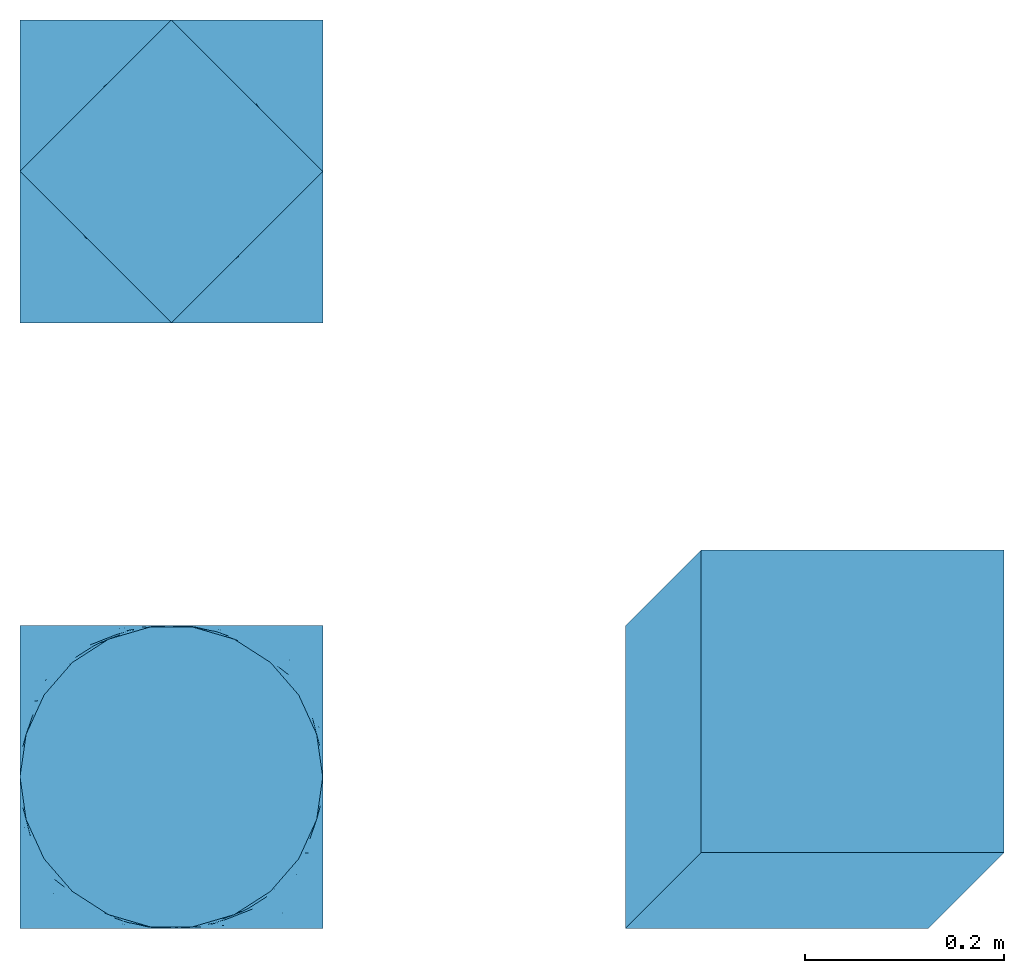
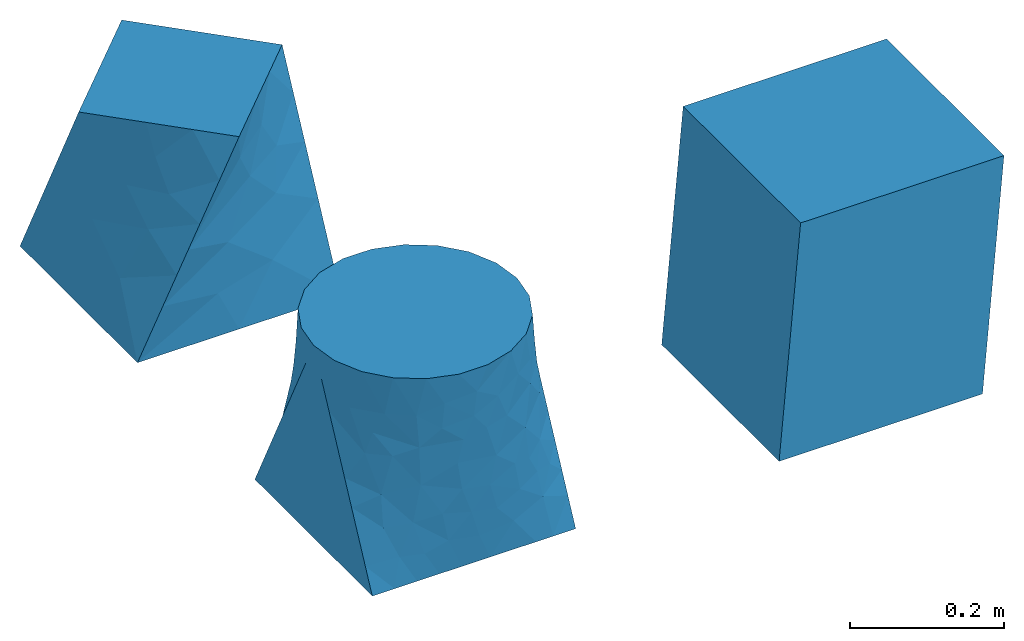
# One storey: 3 walls.
"""IFC2X3 building model written with IfcOpenShell, lengths in feet."""

from ifc_helpers import new_model, entity, si_unit, converted_unit, derived_unit, direction, frame, origin, place, context, subcontext, project, spatial, faceted_brep, type_object, element, save


model = new_model("IFC2X3")

# Units and contexts
model_context = context("Model", 3, precision=0.0001, world=origin(), true_north=direction((6.12303176911189e-17, 1.0)))
body_context = subcontext(model_context, "Body", "Model", "MODEL_VIEW")
ifc_project = project(units=[converted_unit("LENGTHUNIT", "FOOT", entity("IfcRatioMeasure", 0.3048), si_unit("LENGTHUNIT", "METRE"), dimensions=[1, 0, 0, 0, 0, 0, 0]), converted_unit("AREAUNIT", "SQUARE FOOT", entity("IfcRatioMeasure", 0.09290304), si_unit("AREAUNIT", "SQUARE_METRE"), dimensions=[2, 0, 0, 0, 0, 0, 0]), converted_unit("VOLUMEUNIT", "CUBIC FOOT", entity("IfcRatioMeasure", 0.028316846592), si_unit("VOLUMEUNIT", "CUBIC_METRE"), dimensions=[3, 0, 0, 0, 0, 0, 0]), converted_unit("PLANEANGLEUNIT", "DEGREE", entity("IfcRatioMeasure", 0.0174532925199433), si_unit("PLANEANGLEUNIT", "RADIAN"), dimensions=[0, 0, 0, 0, 0, 0, 0]), si_unit("MASSUNIT", "GRAM", prefix="KILO"), derived_unit("MASSDENSITYUNIT", [(si_unit("MASSUNIT", "GRAM", prefix="KILO"), 1), (si_unit("LENGTHUNIT", "METRE"), -3)]), si_unit("TIMEUNIT", "SECOND"), si_unit("FREQUENCYUNIT", "HERTZ"), si_unit("THERMODYNAMICTEMPERATUREUNIT", "DEGREE_CELSIUS"), derived_unit("THERMALTRANSMITTANCEUNIT", [(si_unit("MASSUNIT", "GRAM", prefix="KILO"), 1), (si_unit("THERMODYNAMICTEMPERATUREUNIT", "KELVIN"), -1), (si_unit("TIMEUNIT", "SECOND"), -3)]), derived_unit("VOLUMETRICFLOWRATEUNIT", [(si_unit("LENGTHUNIT", "METRE"), 3), (si_unit("TIMEUNIT", "SECOND"), -1)]), si_unit("ELECTRICCURRENTUNIT", "AMPERE"), si_unit("ELECTRICVOLTAGEUNIT", "VOLT"), si_unit("POWERUNIT", "WATT"), si_unit("FORCEUNIT", "NEWTON"), si_unit("ILLUMINANCEUNIT", "LUX"), si_unit("LUMINOUSFLUXUNIT", "LUMEN"), si_unit("LUMINOUSINTENSITYUNIT", "CANDELA"), derived_unit("USERDEFINED", [(si_unit("MASSUNIT", "GRAM", prefix="KILO"), -1), (si_unit("LENGTHUNIT", "METRE"), -2), (si_unit("TIMEUNIT", "SECOND"), 3), (si_unit("LUMINOUSFLUXUNIT", "LUMEN"), 1)]), derived_unit("LINEARVELOCITYUNIT", [(si_unit("LENGTHUNIT", "METRE"), 1), (si_unit("TIMEUNIT", "SECOND"), -1)]), si_unit("PRESSUREUNIT", "PASCAL"), derived_unit("USERDEFINED", [(si_unit("LENGTHUNIT", "METRE"), -2), (si_unit("MASSUNIT", "GRAM", prefix="KILO"), 1), (si_unit("TIMEUNIT", "SECOND"), -2)])], contexts=[model_context])

# Site, building, storey
site_placement = place(None, origin())
site = spatial("IfcSite", under=ifc_project, at=site_placement, CompositionType="ELEMENT")
building_placement = place(site_placement, origin())
building = spatial("IfcBuilding", under=site, at=building_placement, CompositionType="ELEMENT")
storey_placement = place(building_placement, origin())
storey = spatial("IfcBuildingStorey", under=building, at=storey_placement, Name="Level 1", CompositionType="ELEMENT", Elevation=0.0)

# Walls
wall_type_1 = type_object("IfcWallType", Name="Walls 1", PredefinedType="NOTDEFINED")
wall_1_placement = place(storey_placement, frame((-0.499999999999997, -0.500000000000002, 0.0)))
element("IfcWall", 1, at=wall_1_placement, inside=storey, type_object=wall_type_1, Name="Walls 1:Walls 1", ObjectType="Walls 1:Walls 1", context=body_context, shape_type="Brep", body=[
    faceted_brep([(1.0, 0.0, 0.0), (0.889746791844293, 0.0, 0.0), (0.805126604077855, 0.0, 0.0), (0.720506416311416, 0.0, 0.0), (0.580759624467124, 0.0, 0.0), (0.441012832622831, 0.0, 0.0), (0.330759624467124, 0.0, 0.0), (0.220506416311416, 0.0, 0.0), (0.110253208155708, 0.0, 0.0), (0.0, 0.0, 0.0), (0.0, 1.0, 0.0), (0.110253208155708, 1.0, 0.0), (0.194873395922147, 1.0, 0.0), (0.279493583688586, 1.0, 0.0), (0.419240375532878, 1.0, 0.0), (0.55898716737717, 1.0, 0.0), (0.669240375532878, 1.0, 0.0), (0.779493583688586, 1.0, 0.0), (0.889746791844293, 1.0, 0.0), (1.0, 1.0, 0.0), (1.0, 0.500000000000002, 1.0), (0.979746486807248, 0.640866278420716, 1.0), (0.920626766415589, 0.7703204087278, 1.0), (0.827430366972641, 0.877874787177129, 1.0), (0.707707506500941, 0.954815997677259, 1.0), (0.57115741913664, 0.994910720940465, 1.0), (0.428842580863355, 0.994910720940465, 1.0), (0.292292493499055, 0.954815997677257, 1.0), (0.172569633027356, 0.877874787177126, 1.0), (0.0793732335844083, 0.770320408727796, 1.0), (0.0202535131927508, 0.640866278420711, 1.0), (0.0, 0.499999999999997, 1.0), (0.0202535131927516, 0.359133721579283, 1.0), (0.07937323358441, 0.229679591272199, 1.0), (0.172569633027358, 0.122125212822869, 1.0), (0.292292493499058, 0.0451840023227389, 1.0), (0.428842580863358, 0.00508927905953199, 1.0), (0.571157419136643, 0.00508927905953216, 1.0), (0.707707506500944, 0.0451840023227395, 1.0), (0.827430366972643, 0.12212521282287, 1.0), (0.920626766415591, 0.2296795912722, 1.0), (0.979746486807249, 0.359133721579284, 1.0), (0.0, 0.566151925363885, 0.867696149272224), (0.0, 0.632303850727772, 0.735392298544452), (0.0, 0.698455776091658, 0.60308844781668), (0.0, 0.764607701455546, 0.470784597088905), (0.0, 0.823455776091659, 0.353088447816679), (0.0, 0.882303850727772, 0.235392298544454), (0.0, 0.933848074636112, 0.132303850727775), (0.0, 0.0588480871626567, 0.117696174325314), (0.0, 0.117696174325313, 0.235392348650628), (0.0, 0.176544228203926, 0.353088456407854), (0.0, 0.235392315366583, 0.470784630733168), (0.0, 0.301544253166958, 0.60308850633392), (0.0, 0.36769615768329, 0.735392315366584), (0.0, 0.433848062199621, 0.867696124399248), (0.757017197176466, 0.0674422403782831, 0.849684794978136), (0.86127441293435, 0.145324841999094, 0.84212278587982), (0.141920917585352, 0.140080615055184, 0.811733717234663), (0.616413088488513, 0.0103397471715224, 0.510515551071139), (0.583226274719934, 0.0043372230493256, 0.371454448540285), (0.72097084526604, 0.0338226130972406, 0.417342867665322), (0.849776267484753, 0.12645390141569, 0.732770100211448), (0.515653592398409, 0.000236135867766218, 0.883818607027046), (0.366038709623894, 0.0174541077744, 0.861781446516488), (0.499999979177048, 0.0, 0.760891658883891), (0.252836369415598, 0.0609001946961555, 0.810403815477062), (0.354514701637022, 0.0194400855606597, 0.735414056458186), (0.941110326458552, 0.248356510801277, 0.84968478747674), (1.0, 0.433848074636111, 0.867696149272224), (0.67940057306952, 0.0289607421539577, 0.684433992670568), (0.795731673028418, 0.0745753431820014, 0.554129477798903), (0.16068747856237, 0.106681123880739, 0.606629587667518), (0.109578540638195, 0.11459706935301, 0.418702420722298), (0.262292635672884, 0.0418228934501774, 0.458948207568247), (0.0437324972356253, 0.268445369888635, 0.801544242732555), (0.0721772541138937, 0.186598710925087, 0.603088466442167), (0.260753678036918, 0.0515044057474023, 0.64888846403325), (0.101294141878498, 0.171387659756256, 0.70951726536301), (0.101765332269067, 0.0826796673749913, 0.267954315286302), (0.223935870161411, 0.0399967995170207, 0.278852137072948), (0.565117280794555, 0.00369614575750493, 0.67589412627217), (0.450883079913483, 0.00206744369183098, 0.653250228508571), (0.89216557801141, 0.118139044305108, 0.429955188659176), (1.0, 0.235392298544452, 0.470784597088905), (0.937007672081389, 0.198619614631399, 0.607850394207608), (0.628174730663663, 0.0156186607234066, 0.812192774978989), (0.953012804727175, 0.24889982754745, 0.731724063191964), (0.152440156249403, 0.0327726145620926, 0.130177837941231), (0.527940892776347, 0.000214835338726793, 0.128507843858333), (0.70308915029569, 0.0120184609926423, 0.138334262902587), (0.744287356805821, 0.0310473672176885, 0.277682459355863), (0.618265004846732, 0.00637614198855196, 0.237606556011806), (1.0, 0.301544223908339, 0.60308844781668), (0.442937021056287, 0.00213535034225137, 0.400399859927627), (1.0, 0.0661519253638875, 0.132303850727775), (0.422853395509264, 0.00465825573982376, 0.54077192065932), (0.352201420213089, 0.0118295364385816, 0.298145323069812), (0.376428416935318, 0.00490276932154543, 0.154234560036514), (0.488544710868071, 6.49568121827704e-05, 0.266210865256215), (0.810347749233671, 0.0660190099262035, 0.392123661289816), (0.868487564693337, 0.0504441767336091, 0.183848051981968), (1.0, 0.117696149272227, 0.235392298544454), (0.936407353414507, 0.109169103430892, 0.294240360984303), (0.852390754642082, 0.0716812784062547, 0.306950602242738), (0.265622418367823, 0.0139367961617777, 0.118762404485821), (1.0, 0.367696149272225, 0.735392298544452), (1.0, 0.176544223908339, 0.353088447816679), (1.0, 0.941151912837343, 0.117696174325314), (1.0, 0.882303825674686, 0.235392348650628), (1.0, 0.823455771796074, 0.353088456407854), (1.0, 0.764607684633417, 0.470784630733168), (1.0, 0.698455746833041, 0.60308850633392), (1.0, 0.632303842316709, 0.735392315366584), (1.0, 0.566151937800378, 0.867696124399248), (0.242982802823533, 0.932557759621714, 0.849684794978136), (0.138725587065649, 0.854675158000903, 0.84212278587982), (0.858079082414647, 0.859919384944814, 0.811733717234663), (0.383586911511488, 0.989660252828476, 0.510515551071139), (0.416773725280067, 0.995662776950673, 0.371454448540285), (0.279029154733961, 0.966177386902758, 0.417342867665322), (0.150223732515247, 0.873546098584307, 0.732770100211448), (0.48434640760159, 0.999763864132231, 0.883818607027046), (0.633961290376105, 0.982545892225598, 0.861781446516488), (0.500000020822951, 1.0, 0.760891658883891), (0.747163630584401, 0.939099805303843, 0.810403815477062), (0.645485298362977, 0.980559914439338, 0.735414056458186), (0.0588896735414475, 0.751643489198719, 0.84968478747674), (0.320599426930479, 0.97103925784604, 0.684433992670568), (0.204268326971582, 0.925424656817996, 0.554129477798903), (0.83931252143763, 0.89331887611926, 0.606629587667518), (0.890421459361806, 0.885402930646989, 0.418702420722298), (0.737707364327117, 0.958177106549822, 0.458948207568247), (0.956267502764375, 0.731554630111364, 0.801544242732555), (0.927822745886107, 0.813401289074912, 0.603088466442167), (0.739246321963082, 0.948495594252596, 0.64888846403325), (0.898705858121502, 0.828612340243743, 0.70951726536301), (0.898234667730934, 0.917320332625008, 0.267954315286302), (0.77606412983859, 0.960003200482979, 0.278852137072948), (0.434882719205444, 0.996303854242493, 0.67589412627217), (0.549116920086517, 0.997932556308167, 0.653250228508571), (0.10783442198859, 0.88186095569489, 0.429955188659176), (0.0629923279186115, 0.801380385368598, 0.607850394207608), (0.371825269336336, 0.984381339276591, 0.812192774978989), (0.0469871952728255, 0.751100172452546, 0.731724063191964), (0.847559843750599, 0.967227385437907, 0.130177837941231), (0.472059107223654, 0.999785164661273, 0.128507843858333), (0.296910849704311, 0.987981539007357, 0.138334262902587), (0.25571264319418, 0.96895263278231, 0.277682459355863), (0.381734995153269, 0.993623858011447, 0.237606556011806), (0.557062978943713, 0.997864649657747, 0.400399859927627), (0.577146604490736, 0.995341744260175, 0.54077192065932), (0.647798579786912, 0.988170463561418, 0.298145323069812), (0.623571583064683, 0.995097230678454, 0.154234560036514), (0.51145528913193, 0.999935043187816, 0.266210865256215), (0.18965225076633, 0.933980990073795, 0.392123661289816), (0.131512435306664, 0.94955582326639, 0.183848051981968), (0.063592646585494, 0.890830896569107, 0.294240360984303), (0.147609245357919, 0.928318721593744, 0.306950602242738), (0.734377581632179, 0.986063203838222, 0.118762404485821)], [[[0, 1, 2, 3, 4, 5, 6, 7, 8, 9, 10, 11, 12, 13, 14, 15, 16, 17, 18, 19]], [[20, 21, 22, 23, 24, 25, 26, 27, 28, 29, 30, 31, 32, 33, 34, 35, 36, 37, 38, 39, 40, 41]], [[42, 43, 44, 45, 46, 47, 48, 10, 9, 49, 50, 51, 52, 53, 54, 55, 31]], [[56, 57, 39]], [[58, 34, 33]], [[59, 60, 61]], [[57, 56, 62]], [[63, 36, 64]], [[65, 63, 64]], [[58, 66, 34]], [[67, 65, 64]], [[57, 40, 39]], [[68, 69, 41]], [[68, 41, 40]], [[62, 70, 71]], [[35, 64, 36]], [[72, 73, 74]], [[54, 75, 55]], [[75, 54, 76]], [[72, 77, 78]], [[73, 79, 80]], [[81, 65, 82]], [[56, 39, 38]], [[83, 84, 85]], [[86, 38, 63]], [[56, 70, 62]], [[71, 85, 62]], [[33, 32, 75]], [[65, 67, 82]], [[58, 75, 78]], [[87, 62, 85]], [[69, 20, 41]], [[63, 38, 37]], [[56, 86, 70]], [[66, 35, 34]], [[66, 77, 67]], [[55, 75, 32]], [[32, 31, 55]], [[71, 70, 59]], [[76, 54, 53, 52]], [[75, 58, 33]], [[73, 76, 52]], [[78, 77, 58]], [[7, 88, 8]], [[89, 4, 90]], [[91, 60, 92]], [[85, 84, 93]], [[59, 94, 60]], [[1, 0, 95]], [[49, 9, 8]], [[79, 88, 80]], [[83, 85, 71]], [[85, 93, 87]], [[74, 96, 77]], [[97, 98, 99]], [[100, 71, 61]], [[101, 102, 103]], [[102, 101, 95]], [[83, 104, 103]], [[73, 80, 74]], [[73, 51, 79]], [[98, 97, 80]], [[94, 59, 96]], [[74, 97, 94]], [[70, 81, 59]], [[5, 98, 6]], [[6, 98, 105]], [[89, 92, 99]], [[80, 88, 105]], [[101, 104, 91]], [[90, 2, 101]], [[101, 91, 90]], [[1, 95, 101]], [[94, 97, 99]], [[74, 80, 97]], [[94, 99, 60]], [[74, 94, 96]], [[92, 60, 99]], [[61, 60, 91]], [[91, 104, 100]], [[71, 59, 61]], [[5, 89, 98]], [[90, 91, 92]], [[98, 89, 99]], [[90, 4, 3, 2]], [[5, 4, 89]], [[90, 92, 89]], [[66, 67, 64]], [[82, 77, 96]], [[66, 64, 35]], [[77, 66, 58]], [[77, 82, 67]], [[96, 59, 81]], [[81, 82, 96]], [[86, 81, 70]], [[75, 76, 78]], [[78, 76, 72]], [[73, 72, 76]], [[74, 77, 72]], [[86, 63, 65]], [[36, 63, 37]], [[86, 65, 81]], [[38, 86, 56]], [[80, 105, 98]], [[8, 88, 49]], [[79, 51, 50, 49]], [[6, 105, 7]], [[49, 88, 79]], [[51, 73, 52]], [[7, 105, 88]], [[87, 69, 68]], [[62, 68, 57]], [[40, 57, 68]], [[69, 87, 93, 106]], [[62, 87, 68]], [[103, 102, 107]], [[107, 84, 83]], [[100, 104, 83]], [[83, 103, 107]], [[101, 103, 104]], [[71, 100, 83]], [[91, 100, 61]], [[2, 1, 101]], [[0, 19, 108, 109, 110, 111, 112, 113, 114, 20, 69, 106, 93, 84, 107, 102, 95]], [[115, 116, 28]], [[117, 23, 22]], [[118, 119, 120]], [[116, 115, 121]], [[122, 25, 123]], [[124, 122, 123]], [[117, 125, 23]], [[126, 124, 123]], [[116, 29, 28]], [[127, 42, 30]], [[127, 30, 29]], [[121, 128, 129]], [[24, 123, 25]], [[130, 131, 132]], [[113, 133, 114]], [[133, 113, 134]], [[130, 135, 136]], [[131, 137, 138]], [[139, 124, 140]], [[115, 28, 27]], [[141, 45, 142]], [[143, 27, 122]], [[115, 128, 121]], [[129, 142, 121]], [[22, 21, 133]], [[124, 126, 140]], [[117, 133, 136]], [[144, 121, 142]], [[42, 31, 30]], [[122, 27, 26]], [[115, 143, 128]], [[125, 24, 23]], [[125, 135, 126]], [[114, 133, 21]], [[21, 20, 114]], [[129, 128, 118]], [[134, 113, 112, 111]], [[133, 117, 22]], [[131, 134, 111]], [[136, 135, 117]], [[17, 145, 18]], [[146, 14, 147]], [[148, 119, 149]], [[142, 45, 44]], [[118, 150, 119]], [[11, 10, 48]], [[108, 19, 18]], [[137, 145, 138]], [[141, 142, 129]], [[142, 44, 144]], [[132, 151, 135]], [[152, 153, 154]], [[155, 129, 120]], [[156, 47, 157]], [[47, 156, 48]], [[141, 158, 157]], [[131, 138, 132]], [[131, 110, 137]], [[153, 152, 138]], [[150, 118, 151]], [[132, 152, 150]], [[128, 139, 118]], [[15, 153, 16]], [[16, 153, 159]], [[146, 149, 154]], [[138, 145, 159]], [[156, 158, 148]], [[147, 12, 156]], [[156, 148, 147]], [[11, 48, 156]], [[150, 152, 154]], [[132, 138, 152]], [[150, 154, 119]], [[132, 150, 151]], [[149, 119, 154]], [[120, 119, 148]], [[148, 158, 155]], [[129, 118, 120]], [[15, 146, 153]], [[147, 148, 149]], [[153, 146, 154]], [[147, 14, 13, 12]], [[15, 14, 146]], [[147, 149, 146]], [[125, 126, 123]], [[140, 135, 151]], [[125, 123, 24]], [[135, 125, 117]], [[135, 140, 126]], [[151, 118, 139]], [[139, 140, 151]], [[143, 139, 128]], [[133, 134, 136]], [[136, 134, 130]], [[131, 130, 134]], [[132, 135, 130]], [[143, 122, 124]], [[25, 122, 26]], [[143, 124, 139]], [[27, 143, 115]], [[138, 159, 153]], [[18, 145, 108]], [[137, 110, 109, 108]], [[16, 159, 17]], [[108, 145, 137]], [[110, 131, 111]], [[17, 159, 145]], [[144, 42, 127]], [[121, 127, 116]], [[29, 116, 127]], [[42, 144, 44, 43]], [[121, 144, 127]], [[157, 47, 46]], [[46, 45, 141]], [[155, 158, 141]], [[141, 157, 46]], [[156, 157, 158]], [[129, 155, 141]], [[148, 155, 120]], [[12, 11, 156]]]),
])
wall_type_2 = type_object("IfcWallType", Name="Walls 1", PredefinedType="NOTDEFINED")
wall_2_placement = place(storey_placement, frame((1.5, -0.500000000000008, 0.0)))
element("IfcWall", 2, at=wall_2_placement, inside=storey, type_object=wall_type_2, Name="Walls 2:Walls 1", ObjectType="Walls 2:Walls 1", context=body_context, shape_type="Brep", body=[
    faceted_brep([(1.0, 0.0, 0.0), (0.0, 0.0, 0.0), (0.0, 1.0, 0.0), (1.0, 1.0, 0.0), (1.25, 0.249999999999999, 1.0), (1.25, 1.25, 1.0), (0.25, 1.25, 1.0), (0.25, 0.249999999999999, 1.0)], [[[0, 1, 2, 3]], [[4, 5, 6, 7]], [[4, 7, 1, 0]], [[7, 6, 2, 1]], [[6, 5, 3, 2]], [[5, 4, 0, 3]]]),
])
wall_type_3 = type_object("IfcWallType", Name="Walls 1", PredefinedType="NOTDEFINED")
wall_3_placement = place(storey_placement, frame((-0.499999999999994, 1.5, 0.0), z_axis=(0.0, 0.0, 1.0), x_axis=(0.0, 1.0, 0.0)))
element("IfcWall", 3, at=wall_3_placement, inside=storey, type_object=wall_type_3, Name="Walls 3:Walls 1", ObjectType="Walls 3:Walls 1", context=body_context, shape_type="Brep", body=[
    faceted_brep([(0.5, -1.0, 0.0), (0.0, -1.0, 0.0), (0.0, -0.500000000000001, 0.0), (0.0, 0.0, 0.0), (0.5, 0.0, 0.0), (1.0, 0.0, 0.0), (1.0, -0.500000000000001, 0.0), (1.0, -1.0, 0.0), (0.789573089760387, -0.289573089760389, 1.0), (0.644786544880193, -0.144786544880195, 1.0), (0.499999999999998, 0.0, 1.0), (0.289573089760387, -0.210426910239611, 1.0), (0.144786544880193, -0.355213455119804, 1.0), (0.0, -0.499999999999996, 1.0), (0.210426910239614, -0.710426910239611, 1.0), (0.355213455119809, -0.855213455119806, 1.0), (0.500000000000003, -1.0, 1.0), (0.710426910239615, -0.789573089760389, 1.0), (0.855213455119808, -0.644786544880197, 1.0), (1.0, -0.500000000000004, 1.0), (0.920125771841567, -0.288193622770141, 0.237369078975357), (0.926742559775728, -0.511513811720389, 0.411656509577509), (0.965690423758283, -0.583888559036228, 0.194216435330846), (0.846939706201246, -0.357872598284681, 0.653475678020958), (0.886520867073604, -0.430042051859978, 0.798196447006644), (1.0, -0.750000000000002, 0.5), (0.764864367810861, -0.254263895707651, 0.83401522599708), (0.745902000031234, -0.169272887605611, 0.684258607849023), (0.596524360354119, 0.0, 0.806951279291759), (0.822042303355063, -0.216126876511715, 0.499999963673414), (0.693048720708241, 0.0, 0.613902558583517), (1.0, -0.596524362492216, 0.806951275015574), (1.0, -0.693048720708244, 0.613902558583517), (0.806951279291759, 0.0, 0.386097441416482), (0.749999999999999, 0.0, 0.5), (0.90347563964588, 0.0, 0.193048720708241), (0.87500000161114, 0.0, 0.24999999677772), (1.0, -0.806951279291761, 0.386097441416483), (1.0, -0.874999998388862, 0.25000000322228), (1.0, -0.903475639645881, 0.193048720708242), (0.711806377229861, -0.920125771841567, 0.237369078975357), (0.488486188279613, -0.926742559775729, 0.411656509577509), (0.416111440963775, -0.965690423758284, 0.194216435330846), (0.642127401715323, -0.846939706201247, 0.653475678020958), (0.569957948140026, -0.886520867073604, 0.798196447006644), (0.250000000000002, -1.0, 0.5), (0.745736104292353, -0.764864367810863, 0.834015225997081), (0.830727112394391, -0.745902000031236, 0.684258607849023), (0.783873123488287, -0.822042303355065, 0.499999963673414), (0.403475637507789, -1.0, 0.806951275015574), (0.30695127929176, -1.0, 0.613902558583517), (0.193048720708242, -1.0, 0.386097441416482), (0.124999998388861, -1.0, 0.24999999677772), (0.096524360354121, -1.0, 0.193048720708241), (0.0798742281584344, -0.71180637722986, 0.237369078975357), (0.0732574402242732, -0.488486188279612, 0.411656509577509), (0.0343095762417169, -0.416111440963773, 0.194216435330846), (0.153060293798755, -0.64212740171532, 0.653475678020958), (0.113479132926398, -0.569957948140022, 0.798196447006644), (0.0, -0.249999999999999, 0.5), (0.23513563218914, -0.74573610429235, 0.83401522599708), (0.254097999968767, -0.83072711239439, 0.684258607849023), (0.177957696644938, -0.783873123488286, 0.499999963673414), (0.0, -0.403475637507784, 0.806951275015574), (0.0, -0.306951279291757, 0.613902558583517), (0.0, -0.193048720708241, 0.386097441416483), (0.0, -0.12500000161114, 0.25000000322228), (0.0, -0.0965243603541208, 0.193048720708241), (0.28819362277014, -0.079874228158434, 0.237369078975357), (0.511513811720387, -0.0732574402242727, 0.411656509577509), (0.583888559036226, -0.0343095762417174, 0.194216435330846), (0.357872598284678, -0.153060293798753, 0.653475678020958), (0.430042051859975, -0.113479132926396, 0.798196447006644), (0.254263895707648, -0.235135632189138, 0.834015225997081), (0.169272887605609, -0.254097999968764, 0.684258607849023), (0.216126876511714, -0.177957696644936, 0.499999963673414)], [[[0, 1, 2, 3, 4, 5, 6, 7]], [[8, 9, 10, 11, 12, 13, 14, 15, 16, 17, 18, 19]], [[20, 21, 22]], [[23, 24, 25]], [[26, 27, 28]], [[21, 23, 25]], [[27, 29, 30]], [[19, 31, 32, 25, 24]], [[24, 23, 26]], [[23, 29, 27]], [[28, 10, 9]], [[29, 33, 34, 30]], [[20, 5, 35, 36, 33]], [[20, 33, 29]], [[21, 29, 23]], [[5, 20, 6]], [[7, 6, 22]], [[20, 29, 21]], [[22, 6, 20]], [[21, 25, 37, 38]], [[9, 8, 26]], [[27, 30, 28]], [[27, 26, 23]], [[9, 26, 28]], [[8, 19, 24]], [[8, 24, 26]], [[21, 38, 22]], [[22, 38, 39, 7]], [[40, 41, 42]], [[43, 44, 45]], [[46, 47, 31]], [[41, 43, 45]], [[47, 48, 32]], [[16, 49, 50, 45, 44]], [[44, 43, 46]], [[43, 48, 47]], [[31, 19, 18]], [[48, 37, 25, 32]], [[40, 7, 39, 38, 37]], [[40, 37, 48]], [[41, 48, 43]], [[7, 40, 0]], [[1, 0, 42]], [[40, 48, 41]], [[42, 0, 40]], [[41, 45, 51, 52]], [[18, 17, 46]], [[47, 32, 31]], [[47, 46, 43]], [[18, 46, 31]], [[17, 16, 44]], [[17, 44, 46]], [[41, 52, 42]], [[42, 52, 53, 1]], [[54, 55, 56]], [[57, 58, 59]], [[60, 61, 49]], [[55, 57, 59]], [[61, 62, 50]], [[13, 63, 64, 59, 58]], [[58, 57, 60]], [[57, 62, 61]], [[49, 16, 15]], [[62, 51, 45, 50]], [[54, 1, 53, 52, 51]], [[54, 51, 62]], [[55, 62, 57]], [[1, 54, 2]], [[3, 2, 56]], [[54, 62, 55]], [[56, 2, 54]], [[55, 59, 65, 66]], [[15, 14, 60]], [[61, 50, 49]], [[61, 60, 57]], [[15, 60, 49]], [[14, 13, 58]], [[14, 58, 60]], [[55, 66, 56]], [[56, 66, 67, 3]], [[68, 69, 70]], [[71, 72, 34]], [[73, 74, 63]], [[69, 71, 34]], [[74, 75, 64]], [[10, 28, 30, 34, 72]], [[72, 71, 73]], [[71, 75, 74]], [[63, 13, 12]], [[75, 65, 59]], [[68, 3, 67, 66, 65]], [[68, 65, 75]], [[69, 75, 71]], [[3, 68, 4]], [[5, 4, 70]], [[68, 75, 69]], [[70, 4, 68]], [[69, 34, 33, 36]], [[12, 11, 73]], [[74, 64, 63]], [[74, 73, 71]], [[12, 73, 63]], [[11, 10, 72]], [[11, 72, 73]], [[69, 36, 70]], [[70, 36, 35, 5]], [[75, 59, 64]]]),
])

save(model, "model.ifc")
